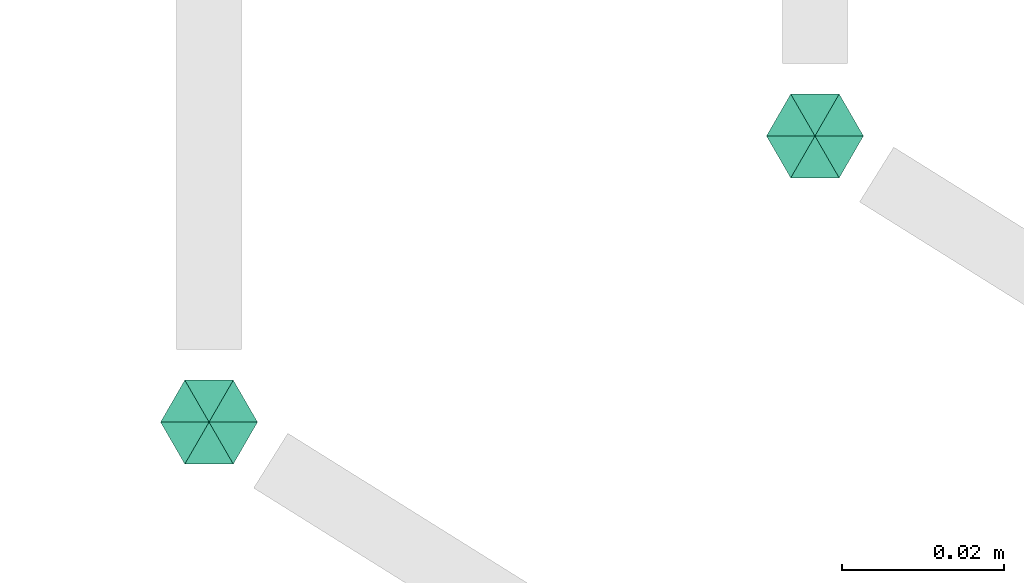
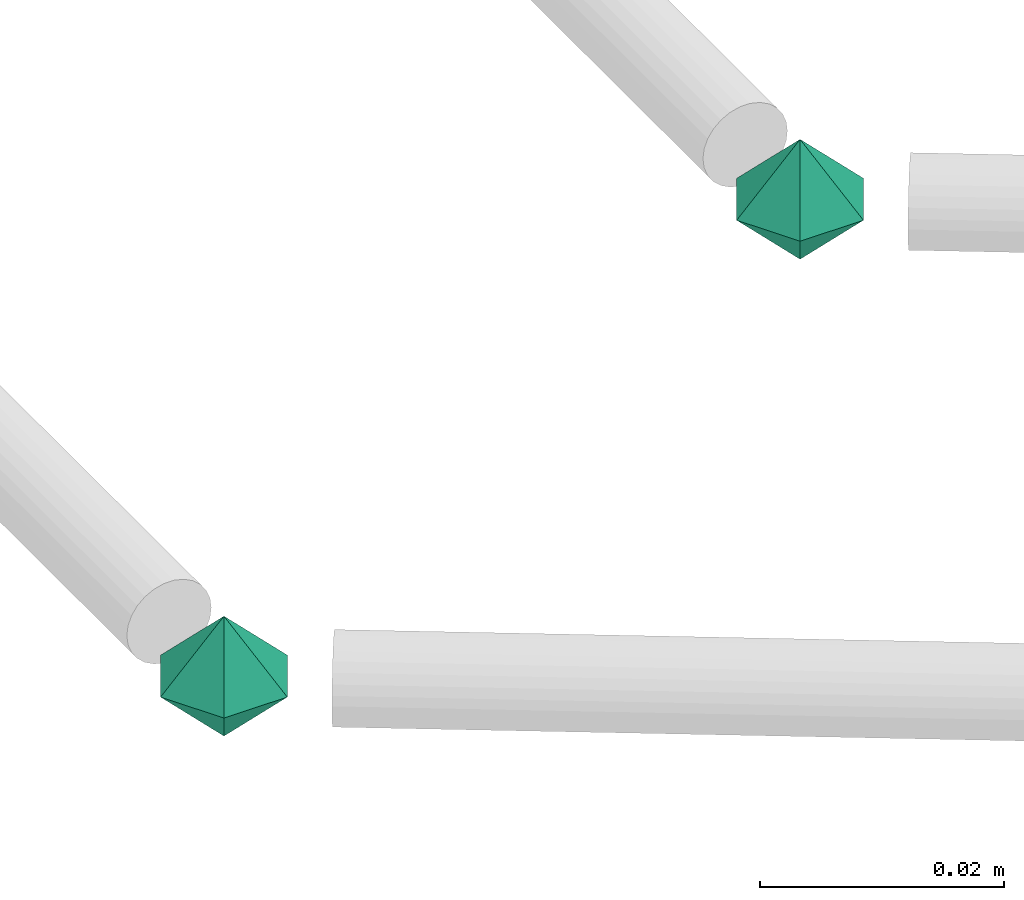
# One storey, part 49 of 65: 2 flow fittings.
"""IFC2X3 building model written with IfcOpenShell, lengths in millimetres."""

from ifc_helpers import new_model, entity, si_unit, converted_unit, derived_unit, direction, frame, origin, place, context, subcontext, project, spatial, faceted_brep, source, transform, mapped, material, material_list, type_object, type_shapes, element, save


model = new_model("IFC2X3")

# Units and contexts
model_context = context("Model", 3, precision=0.01, world=origin(), true_north=direction((6.12303176911189e-17, 1.0)))
body_context = subcontext(model_context, "Body", "Model", "MODEL_VIEW")
ifc_project = project(units=[si_unit("LENGTHUNIT", "METRE", prefix="MILLI"), si_unit("AREAUNIT", "SQUARE_METRE"), si_unit("VOLUMEUNIT", "CUBIC_METRE"), converted_unit("PLANEANGLEUNIT", "DEGREE", entity("IfcRatioMeasure", 0.0174532925199433), si_unit("PLANEANGLEUNIT", "RADIAN"), dimensions=[0, 0, 0, 0, 0, 0, 0]), si_unit("MASSUNIT", "GRAM", prefix="KILO"), derived_unit("MASSDENSITYUNIT", [(si_unit("MASSUNIT", "GRAM", prefix="KILO"), 1), (si_unit("LENGTHUNIT", "METRE"), -3)]), derived_unit("MOMENTOFINERTIAUNIT", [(si_unit("LENGTHUNIT", "METRE"), 4)]), si_unit("TIMEUNIT", "SECOND"), si_unit("FREQUENCYUNIT", "HERTZ"), si_unit("THERMODYNAMICTEMPERATUREUNIT", "DEGREE_CELSIUS"), derived_unit("THERMALTRANSMITTANCEUNIT", [(si_unit("MASSUNIT", "GRAM", prefix="KILO"), 1), (si_unit("THERMODYNAMICTEMPERATUREUNIT", "KELVIN"), -1), (si_unit("TIMEUNIT", "SECOND"), -3)]), derived_unit("VOLUMETRICFLOWRATEUNIT", [(si_unit("LENGTHUNIT", "METRE"), 3), (si_unit("TIMEUNIT", "SECOND"), -1)]), derived_unit("MASSFLOWRATEUNIT", [(si_unit("MASSUNIT", "GRAM", prefix="KILO"), 1), (si_unit("TIMEUNIT", "SECOND"), -1)]), derived_unit("ROTATIONALFREQUENCYUNIT", [(si_unit("TIMEUNIT", "SECOND"), -1)]), si_unit("ELECTRICCURRENTUNIT", "AMPERE"), si_unit("ELECTRICVOLTAGEUNIT", "VOLT"), si_unit("POWERUNIT", "WATT"), si_unit("FORCEUNIT", "NEWTON", prefix="KILO"), si_unit("ILLUMINANCEUNIT", "LUX"), si_unit("LUMINOUSFLUXUNIT", "LUMEN"), si_unit("LUMINOUSINTENSITYUNIT", "CANDELA"), derived_unit("USERDEFINED", [(si_unit("MASSUNIT", "GRAM", prefix="KILO"), -1), (si_unit("LENGTHUNIT", "METRE"), -2), (si_unit("TIMEUNIT", "SECOND"), 3), (si_unit("LUMINOUSFLUXUNIT", "LUMEN"), 1)]), derived_unit("LINEARVELOCITYUNIT", [(si_unit("LENGTHUNIT", "METRE"), 1), (si_unit("TIMEUNIT", "SECOND"), -1)]), si_unit("PRESSUREUNIT", "PASCAL"), derived_unit("USERDEFINED", [(si_unit("LENGTHUNIT", "METRE"), -2), (si_unit("MASSUNIT", "GRAM", prefix="KILO"), 1), (si_unit("TIMEUNIT", "SECOND"), -2)]), derived_unit("LINEARFORCEUNIT", [(si_unit("MASSUNIT", "GRAM", prefix="KILO"), 1), (si_unit("LENGTHUNIT", "METRE"), 1), (si_unit("TIMEUNIT", "SECOND"), -2), (si_unit("LENGTHUNIT", "METRE"), -1)]), derived_unit("PLANARFORCEUNIT", [(si_unit("MASSUNIT", "GRAM", prefix="KILO"), 1), (si_unit("LENGTHUNIT", "METRE"), 1), (si_unit("TIMEUNIT", "SECOND"), -2), (si_unit("LENGTHUNIT", "METRE"), -2)])], contexts=[model_context])

# Site, building, storey
site_placement = place(None, frame((0.0, -0.00077364408347762, 0.0)))
site = spatial("IfcSite", under=ifc_project, at=site_placement, CompositionType="ELEMENT")
building_placement = place(site_placement, origin())
building = spatial("IfcBuilding", under=site, at=building_placement, CompositionType="ELEMENT")
storey_placement = place(building_placement, frame((0.0, 0.0, 19800.0)))
storey = spatial("IfcBuildingStorey", under=building, at=storey_placement, CompositionType="ELEMENT", Elevation=19800.0)

# Flow fittings
ifc_material_1 = material()
ifc_material_2 = material()
ifc_material_list = material_list([ifc_material_2, ifc_material_1])
pipe_fitting_type = type_object("IfcPipeFittingType", PredefinedType="NOTDEFINED", material=ifc_material_list)
shared_shape = source(origin(), body_context, "Body", "Brep", [
    faceted_brep([(5.19615242271291, 3.0, 0.0), (1.81736279215797e-07, 1.95255430990304e-07, -6.0), (0.0, 6.0, 0.0), (5.19615242271289, -3.0, 0.0), (0.0, -6.0, 0.0), (-5.19615242270038, 3.0, 0.0), (-5.19615242270037, -3.0, 0.0), (-7.73803144365858e-08, 6.63990943561288e-08, 6.0)], [[[0, 1, 2]], [[1, 0, 3]], [[1, 3, 4]], [[5, 1, 6]], [[1, 4, 6]], [[2, 1, 5]], [[5, 7, 2]], [[7, 5, 6]], [[7, 6, 4]], [[0, 7, 3]], [[7, 4, 3]], [[2, 7, 0]]]),
])
type_shapes(pipe_fitting_type, [shared_shape])
for number, where, z_axis, x_axis in (
    (1, (16480.0, 2995.83525953199, 3049.9999149675), (-7.48347027446822e-08, -8.56905489873736e-08, 1.0), (0.0, -1.0, -8.56905489873739e-08)),
    (2, (16405.0, 2960.41836511055, 3050.0), (0.0, 0.0, 1.0), (0.0, -1.0, 0.0)),
):
    element("IfcFlowFitting", number, at=place(storey_placement, frame(where, z_axis=z_axis, x_axis=x_axis)), inside=storey, type_object=pipe_fitting_type, material=ifc_material_1, context=body_context, shape_type="MappedRepresentation", body=[
        mapped(shared_shape, transform((0.0, 0.0, 0.0), scale=1.0)),
    ])

save(model, "model.ifc")
